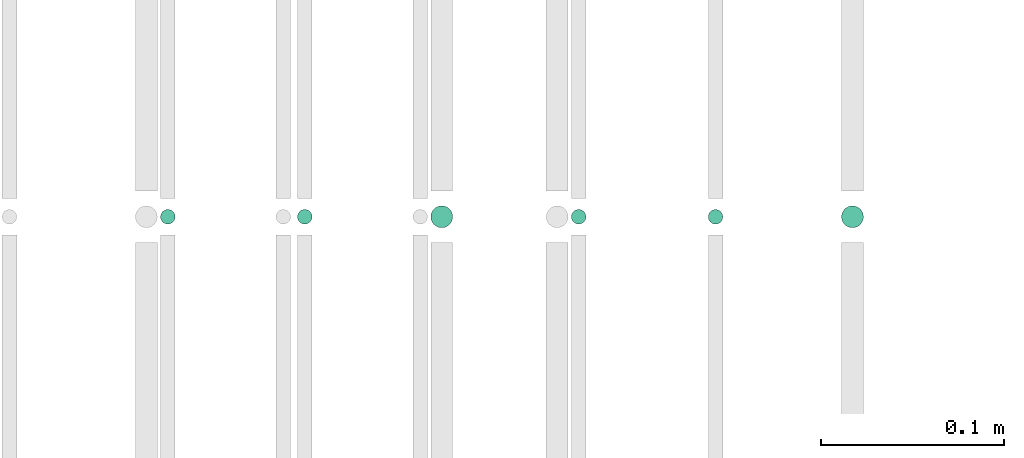
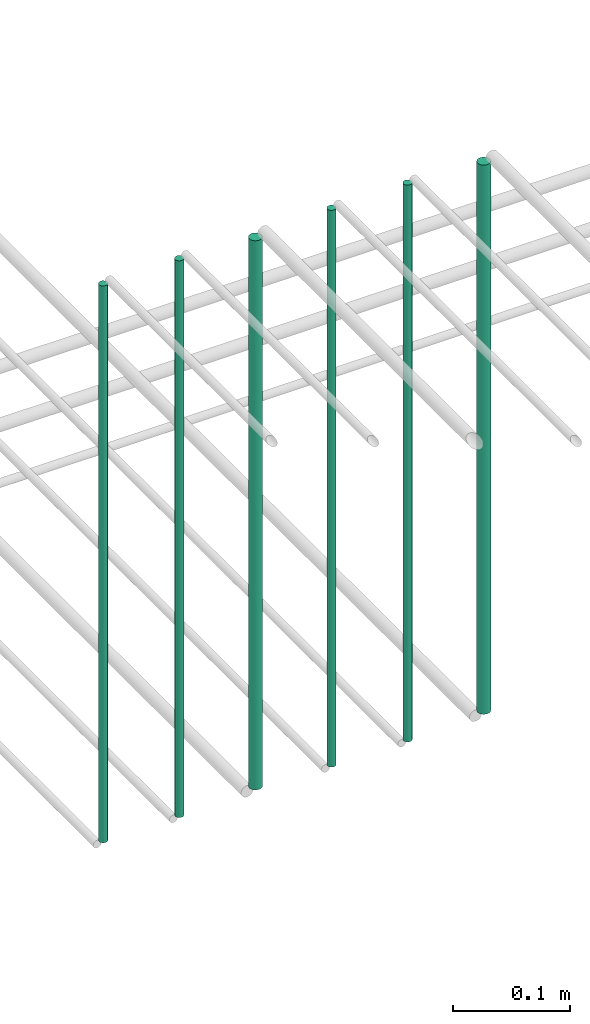
# One storey, part 137 of 331: 6 flow segments.
"""IFC2X3 building model written with IfcOpenShell, lengths in millimetres."""

from ifc_helpers import new_model, entity, si_unit, converted_unit, derived_unit, direction, frame, frame_2d, origin, origin_2d_with_axis, place, context, subcontext, project, spatial, circle, extrude, type_object, element, save


model = new_model("IFC2X3")

# Units and contexts
model_context = context("Model", 3, precision=0.01, world=origin(), true_north=direction((6.12303176911189e-17, 1.0)))
body_context = subcontext(model_context, "Body", "Model", "MODEL_VIEW")
ifc_project = project(units=[si_unit("LENGTHUNIT", "METRE", prefix="MILLI"), si_unit("AREAUNIT", "SQUARE_METRE"), si_unit("VOLUMEUNIT", "CUBIC_METRE"), converted_unit("PLANEANGLEUNIT", "DEGREE", entity("IfcRatioMeasure", 0.0174532925199433), si_unit("PLANEANGLEUNIT", "RADIAN"), dimensions=[0, 0, 0, 0, 0, 0, 0]), si_unit("MASSUNIT", "GRAM", prefix="KILO"), derived_unit("MASSDENSITYUNIT", [(si_unit("MASSUNIT", "GRAM", prefix="KILO"), 1), (si_unit("LENGTHUNIT", "METRE"), -3)]), derived_unit("MOMENTOFINERTIAUNIT", [(si_unit("LENGTHUNIT", "METRE"), 4)]), si_unit("TIMEUNIT", "SECOND"), si_unit("FREQUENCYUNIT", "HERTZ"), si_unit("THERMODYNAMICTEMPERATUREUNIT", "DEGREE_CELSIUS"), derived_unit("THERMALTRANSMITTANCEUNIT", [(si_unit("MASSUNIT", "GRAM", prefix="KILO"), 1), (si_unit("THERMODYNAMICTEMPERATUREUNIT", "KELVIN"), -1), (si_unit("TIMEUNIT", "SECOND"), -3)]), derived_unit("VOLUMETRICFLOWRATEUNIT", [(si_unit("LENGTHUNIT", "METRE"), 3), (si_unit("TIMEUNIT", "SECOND"), -1)]), derived_unit("MASSFLOWRATEUNIT", [(si_unit("MASSUNIT", "GRAM", prefix="KILO"), 1), (si_unit("TIMEUNIT", "SECOND"), -1)]), derived_unit("ROTATIONALFREQUENCYUNIT", [(si_unit("TIMEUNIT", "SECOND"), -1)]), si_unit("ELECTRICCURRENTUNIT", "AMPERE"), si_unit("ELECTRICVOLTAGEUNIT", "VOLT"), si_unit("POWERUNIT", "WATT"), si_unit("FORCEUNIT", "NEWTON", prefix="KILO"), si_unit("ILLUMINANCEUNIT", "LUX"), si_unit("LUMINOUSFLUXUNIT", "LUMEN"), si_unit("LUMINOUSINTENSITYUNIT", "CANDELA"), derived_unit("USERDEFINED", [(si_unit("MASSUNIT", "GRAM", prefix="KILO"), -1), (si_unit("LENGTHUNIT", "METRE"), -2), (si_unit("TIMEUNIT", "SECOND"), 3), (si_unit("LUMINOUSFLUXUNIT", "LUMEN"), 1)]), derived_unit("LINEARVELOCITYUNIT", [(si_unit("LENGTHUNIT", "METRE"), 1), (si_unit("TIMEUNIT", "SECOND"), -1)]), si_unit("PRESSUREUNIT", "PASCAL"), derived_unit("USERDEFINED", [(si_unit("LENGTHUNIT", "METRE"), -2), (si_unit("MASSUNIT", "GRAM", prefix="KILO"), 1), (si_unit("TIMEUNIT", "SECOND"), -2)]), derived_unit("LINEARFORCEUNIT", [(si_unit("MASSUNIT", "GRAM", prefix="KILO"), 1), (si_unit("LENGTHUNIT", "METRE"), 1), (si_unit("TIMEUNIT", "SECOND"), -2), (si_unit("LENGTHUNIT", "METRE"), -1)]), derived_unit("PLANARFORCEUNIT", [(si_unit("MASSUNIT", "GRAM", prefix="KILO"), 1), (si_unit("LENGTHUNIT", "METRE"), 1), (si_unit("TIMEUNIT", "SECOND"), -2), (si_unit("LENGTHUNIT", "METRE"), -2)])], contexts=[model_context])

# Site, building, storey
site_placement = place(None, frame((0.0, -0.00077364408347762, 0.0)))
site = spatial("IfcSite", under=ifc_project, at=site_placement, CompositionType="ELEMENT")
building_placement = place(site_placement, origin())
building = spatial("IfcBuilding", under=site, at=building_placement, CompositionType="ELEMENT")
storey_placement = place(building_placement, origin())
storey = spatial("IfcBuildingStorey", under=building, at=storey_placement, CompositionType="ELEMENT", Elevation=0.0)

# Flow segments
pipe_segment_type = type_object("IfcPipeSegmentType", PredefinedType="NOTDEFINED")
flow_segment_1_placement = place(storey_placement, frame((25065.5132663482, 5638.02529159149, 14560.0)))
element("IfcFlowSegment", 1, at=flow_segment_1_placement, inside=storey, type_object=pipe_segment_type, context=body_context, shape_type="SweptSolid", body=[
    extrude(circle(Radius=4.0, at=frame_2d((0.0, -1.08286712929839e-12), x_axis=(1.0, 0.0))), frame((5.59527223591499, 5.59527223591499, 0.0), z_axis=(0.0, 0.0, 1.0), x_axis=(-1.0, 0.0, 0.0)), (0.0, 0.0, 1.0), 580.000000000018),
])
flow_segment_2_placement = place(storey_placement, frame((25140.5132663482, 5638.02529159149, 14560.0)))
element("IfcFlowSegment", 2, at=flow_segment_2_placement, inside=storey, type_object=pipe_segment_type, context=body_context, shape_type="SweptSolid", body=[
    extrude(circle(Radius=4.0, at=origin_2d_with_axis()), frame((5.59527223591499, 5.59527223591607, 0.0), z_axis=(0.0, 0.0, 1.0), x_axis=(-1.0, 0.0, 0.0)), (0.0, 0.0, 1.0), 580.000000000009),
])
flow_segment_3_placement = place(storey_placement, frame((25213.5132663482, 5636.02529159149, 14564.0)))
element("IfcFlowSegment", 3, at=flow_segment_3_placement, inside=storey, type_object=pipe_segment_type, context=body_context, shape_type="SweptSolid", body=[
    extrude(circle(Radius=6.0, at=frame_2d((0.0, -1.08286712929839e-12), x_axis=(1.0, 0.0))), frame((7.59527223591454, 7.59527223591454, 0.0), z_axis=(0.0, 0.0, 1.0), x_axis=(-1.0, 0.0, 0.0)), (0.0, 0.0, 1.0), 572.0),
])
flow_segment_4_placement = place(storey_placement, frame((25290.5132663482, 5638.02529159149, 14560.0)))
element("IfcFlowSegment", 4, at=flow_segment_4_placement, inside=storey, type_object=pipe_segment_type, context=body_context, shape_type="SweptSolid", body=[
    extrude(circle(Radius=4.0, at=origin_2d_with_axis()), frame((5.59527223591499, 5.59527223591607, 0.0), z_axis=(0.0, 0.0, 1.0), x_axis=(-1.0, 0.0, 0.0)), (0.0, 0.0, 1.0), 580.000000000018),
])
flow_segment_5_placement = place(storey_placement, frame((25365.5132663482, 5638.02529159149, 14560.0)))
element("IfcFlowSegment", 5, at=flow_segment_5_placement, inside=storey, type_object=pipe_segment_type, context=body_context, shape_type="SweptSolid", body=[
    extrude(circle(Radius=4.0, at=origin_2d_with_axis()), frame((5.59527223591499, 5.59527223591607, 0.0), z_axis=(0.0, 0.0, 1.0), x_axis=(-1.0, 0.0, 0.0)), (0.0, 0.0, 1.0), 579.999999999998),
])
flow_segment_6_placement = place(storey_placement, frame((25438.5132663482, 5636.02529159149, 14564.0)))
element("IfcFlowSegment", 6, at=flow_segment_6_placement, inside=storey, type_object=pipe_segment_type, context=body_context, shape_type="SweptSolid", body=[
    extrude(circle(Radius=6.0, at=origin_2d_with_axis()), frame((7.59527223591454, 7.59527223591562, 0.0), z_axis=(0.0, 0.0, 1.0), x_axis=(-1.0, 0.0, 0.0)), (0.0, 0.0, 1.0), 572.000000000011),
])

save(model, "model.ifc")
